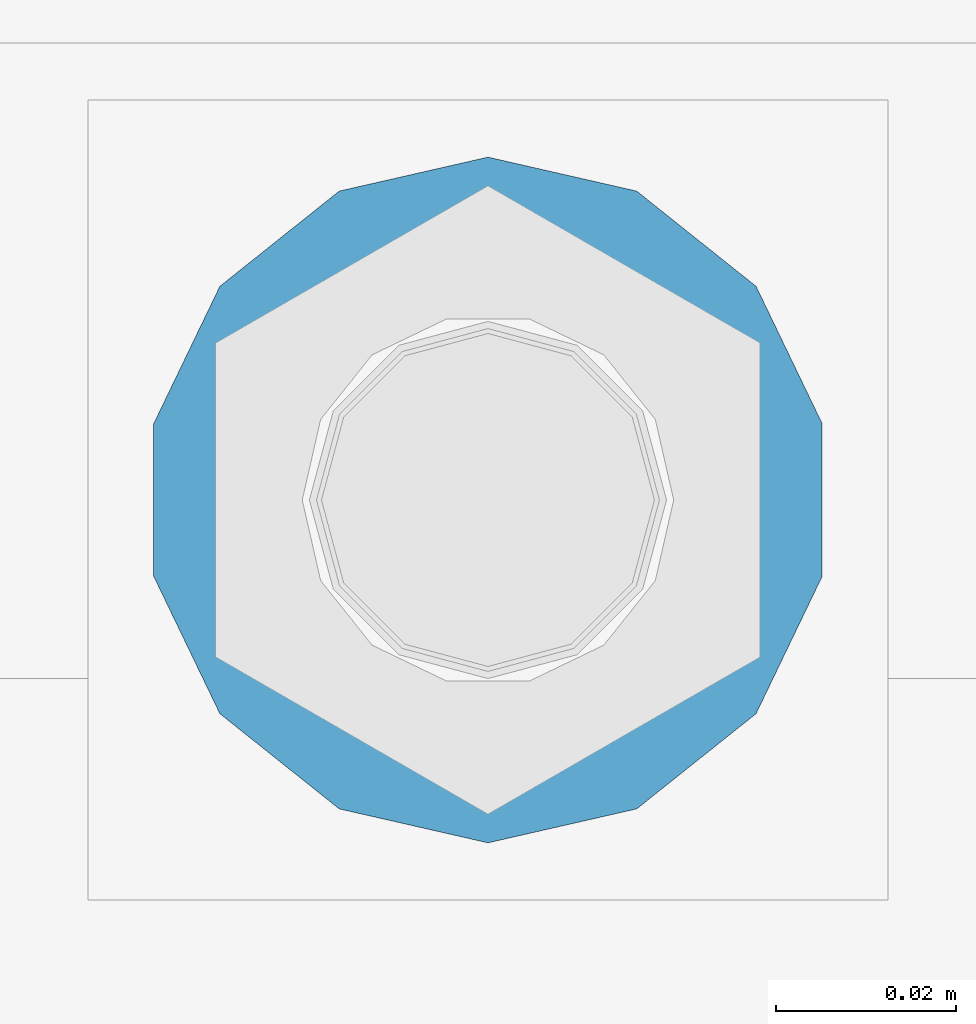
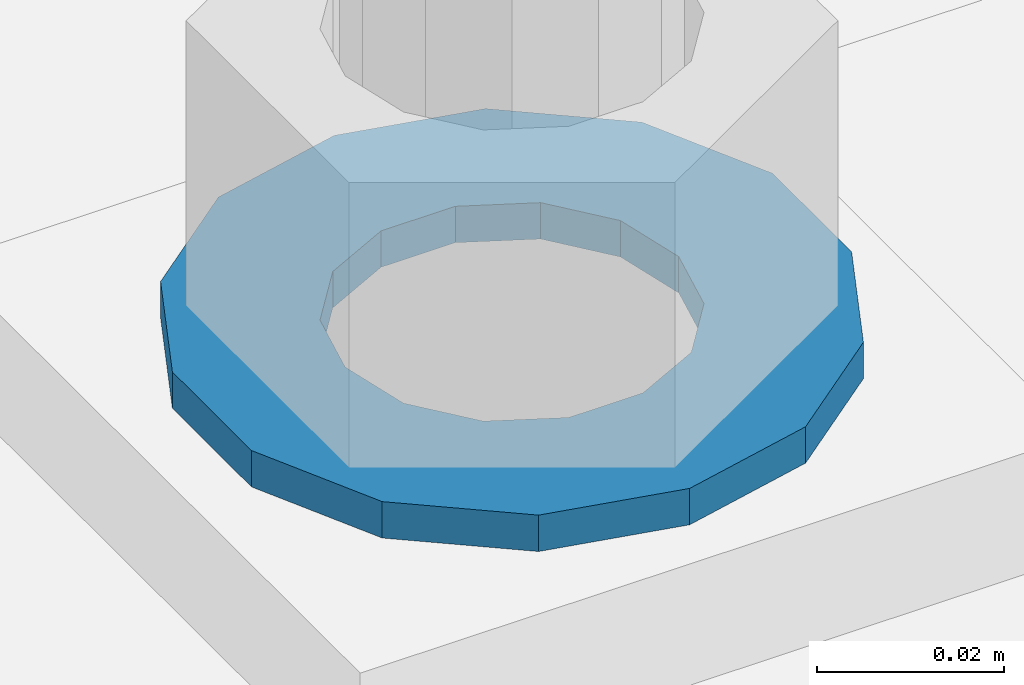
# One storey, part 860 of 1876: 1 column, 1 element without a shape of its own.
"""IFC2X3 building model written with IfcOpenShell, lengths in millimetres."""

import ifcopenshell
import ifcopenshell.guid

model = None  # the IFC model being written
_history = None  # IfcOwnerHistory: only IFC2X3 demands one
_inside = {}  # id of a spatial element -> (the spatial element, [elements in it])
_under = {}  # id of a project, library or spatial element -> (it, [spatial elements below it])
_declared = {}  # id of a project -> (the project, [libraries it declares])
_typed = {}  # id of a type object -> (the type object, [elements of that type])
_made_of = {}  # id of a material, layer set ... -> (it, [elements and type objects made of it])


def new_model(schema):
    """Start an empty IFC model of exactly this schema.

    Asked for "IFC4X3", IfcOpenShell would pick the latest addendum, in which some entities
    have other attributes; the version numbers below select the first issue.
    IFC2X3 requires an IfcOwnerHistory on every rooted entity: one is made here for all.
    """
    global model, _history
    if schema == "IFC4X3":
        model = ifcopenshell.file(schema_version=(4, 3, 0, 0))
    else:
        model = ifcopenshell.file(schema=schema)
    _inside.clear()
    _under.clear()
    _declared.clear()
    _typed.clear()
    _made_of.clear()
    _history = None
    if model.schema == "IFC2X3":
        org = make("IfcOrganization", Name="unknown")
        user = make(
            "IfcPersonAndOrganization",
            ThePerson=make("IfcPerson", FamilyName="unknown"),
            TheOrganization=org,
        )
        app = make(
            "IfcApplication",
            ApplicationDeveloper=org,
            Version="unknown",
            ApplicationFullName="unknown",
            ApplicationIdentifier="unknown",
        )
        _history = make(
            "IfcOwnerHistory",
            OwningUser=user,
            OwningApplication=app,
            ChangeAction="ADDED",
            CreationDate=0,
        )
    return model


def make(cls, **values):
    """One entity of the class cls with the attributes given. An attribute that is None is left unset."""
    return model.create_entity(
        cls, **{name: value for name, value in values.items() if value is not None}
    )


def rooted(cls, **values):
    """An entity with a GlobalId (a new one), such as an element, a storey or a relation."""
    return make(cls, GlobalId=ifcopenshell.guid.new(), OwnerHistory=_history, **values)


def si_unit(unit_type, name, prefix=None):
    """IfcSIUnit, for example si_unit("LENGTHUNIT", "METRE", prefix="MILLI")."""
    return make("IfcSIUnit", UnitType=unit_type, Prefix=prefix, Name=name)


def assignment(units):
    """IfcUnitAssignment: the units of a project."""
    return None if units is None else make("IfcUnitAssignment", Units=units)


def point(xyz):
    """IfcCartesianPoint."""
    return None if xyz is None else make("IfcCartesianPoint", Coordinates=xyz)


def direction(xyz):
    """IfcDirection."""
    return None if xyz is None else make("IfcDirection", DirectionRatios=xyz)


def frame(location, z_axis=None, x_axis=None):
    """IfcAxis2Placement3D, a coordinate frame: its origin and axes. An axis left out is left unset."""
    return make(
        "IfcAxis2Placement3D",
        Location=point(location),
        Axis=direction(z_axis),
        RefDirection=direction(x_axis),
    )


def origin_with_axes():
    """The frame at (0, 0, 0) with the z axis (0, 0, 1) and the x axis (1, 0, 0) written out."""
    return frame((0.0, 0.0, 0.0), z_axis=(0.0, 0.0, 1.0), x_axis=(1.0, 0.0, 0.0))


def place(relative_to, where):
    """IfcLocalPlacement: puts the frame where relative to a parent placement (None: the world)."""
    return make(
        "IfcLocalPlacement", PlacementRelTo=relative_to, RelativePlacement=where
    )


def context(
    kind, dimensions, precision=None, world=None, true_north=None, identifier=None
):
    """IfcGeometricRepresentationContext, for example the 3D "Model" context."""
    return make(
        "IfcGeometricRepresentationContext",
        ContextIdentifier=identifier,
        ContextType=kind,
        CoordinateSpaceDimension=dimensions,
        Precision=precision,
        WorldCoordinateSystem=world,
        TrueNorth=true_north,
    )


def subcontext(parent, identifier, kind, view, scale=None):
    """IfcGeometricRepresentationSubContext, for example "Body" below "Model"."""
    return make(
        "IfcGeometricRepresentationSubContext",
        ContextIdentifier=identifier,
        ContextType=kind,
        ParentContext=parent,
        TargetScale=scale,
        TargetView=view,
    )


def project(units=None, contexts=None):
    """IfcProject with its units and contexts."""
    return rooted(
        "IfcProject",
        Name="project",
        RepresentationContexts=contexts,
        UnitsInContext=assignment(units),
    )


def spatial(cls, under=None, at=None, **own):
    """A site, building, storey or space (cls), placed at a placement, below another one or the project."""
    s = rooted(cls, ObjectPlacement=at, **own)
    if under is not None:
        _under.setdefault(under.id(), (under, []))[1].append(s)
    return s


def faces_of(points, faces, orient=None, outer=None):
    """IfcFace entities. A face is a list of loops; a loop is a list of indices into points, from 0.

    orient and outer hold one flag for each loop. By default every Orientation is true, the
    first loop of a face is its IfcFaceOuterBound and the others are IfcFaceBound.
    """
    made = []
    for i, loops in enumerate(faces):
        bounds = []
        for j, loop in enumerate(loops):
            is_outer = j == 0 if outer is None else outer[i][j]
            bounds.append(
                make(
                    "IfcFaceOuterBound" if is_outer else "IfcFaceBound",
                    Bound=make("IfcPolyLoop", Polygon=[points[k] for k in loop]),
                    Orientation=True if orient is None else orient[i][j],
                )
            )
        made.append(make("IfcFace", Bounds=bounds))
    return made


def faceted_brep(points, faces, orient=None, outer=None, voids=None):
    """IfcFacetedBrep: a solid bounded by flat faces; with voids (closed shells), ...WithVoids."""
    shared = [point(p) for p in points]
    hull = make("IfcClosedShell", CfsFaces=faces_of(shared, faces, orient, outer))
    if voids is None:
        return make("IfcFacetedBrep", Outer=hull)
    return make(
        "IfcFacetedBrepWithVoids",
        Outer=hull,
        Voids=[
            make(cls, CfsFaces=faces_of(shared, fs, o, b)) for cls, fs, o, b in voids
        ],
    )


def shape(context_of_items, identifier, shape_type, items):
    """IfcShapeRepresentation: the items that make up one representation, for example the "Body"."""
    return make(
        "IfcShapeRepresentation",
        ContextOfItems=context_of_items,
        RepresentationIdentifier=identifier,
        RepresentationType=shape_type,
        Items=items,
    )


def material(Name=None, Category=None):
    """IfcMaterial."""
    return make("IfcMaterial", Name=Name, Category=Category)


def made_of(thing, what):
    """Note that an element or type object is made of a material, layer set ...; save() writes the relation."""
    if what is not None:
        _made_of.setdefault(what.id(), (what, []))[1].append(thing)
    return thing


def type_object(cls, material=None, **own):
    """A type object (cls), such as IfcWallType, which elements share."""
    return made_of(rooted(cls, **own), material)


def element(
    cls,
    number,
    at=None,
    inside=None,
    cuts=None,
    type_object=None,
    material=None,
    context=None,
    identifier="Body",
    shape_type=None,
    held_by="IfcProductDefinitionShape",
    body=None,
    shapes=None,
    **own,
):
    """One element of the class cls, such as IfcWall. Its Tag is "e" and its number.

    at: its placement. inside: the storey or other place that contains it. cuts: it is an
    opening in that element (IfcRelVoidsElement). A single representation is given by context,
    identifier, shape_type and body (its items); several are given by shapes. held_by: the class
    of the entity that holds the representations. save() writes the other relations.
    """
    e = rooted(cls, Tag="e%d" % number, ObjectPlacement=at, **own)
    if body is not None:
        shapes = [shape(context, identifier, shape_type, body)]
    if shapes is not None:
        e.Representation = make(held_by, Representations=shapes)
    if inside is not None:
        _inside.setdefault(inside.id(), (inside, []))[1].append(e)
    if cuts is not None:
        rooted(
            "IfcRelVoidsElement", RelatingBuildingElement=cuts, RelatedOpeningElement=e
        )
    if type_object is not None:
        _typed.setdefault(type_object.id(), (type_object, []))[1].append(e)
    return made_of(e, material)


def aggregate(whole, parts):
    """IfcRelAggregates: a whole, such as a stair, and the parts it consists of."""
    return rooted("IfcRelAggregates", RelatingObject=whole, RelatedObjects=parts)


def save(model, path):
    """Write the relations noted so far, then the file.

    IfcRelAggregates (storeys below a building ...), IfcRelContainedInSpatialStructure (elements
    in a storey), IfcRelDefinesByType, IfcRelAssociatesMaterial and IfcRelDeclares: one each for
    every whole, place, type object, material and project.
    """
    for whole, parts in _under.values():
        aggregate(whole, parts)
    for where, things in _inside.values():
        rooted(
            "IfcRelContainedInSpatialStructure",
            RelatedElements=things,
            RelatingStructure=where,
        )
    for kind, things in _typed.values():
        rooted("IfcRelDefinesByType", RelatedObjects=things, RelatingType=kind)
    for what, things in _made_of.values():
        rooted("IfcRelAssociatesMaterial", RelatedObjects=things, RelatingMaterial=what)
    for by, libraries in _declared.values():
        rooted("IfcRelDeclares", RelatingContext=by, RelatedDefinitions=libraries)
    model.write(path)


model = new_model("IFC2X3")

# Units and contexts
model_context = context("Model", 3, precision=1e-05, world=origin_with_axes())
body_context = subcontext(model_context, "Body", "Model", "MODEL_VIEW")
ifc_project = project(units=[si_unit("LENGTHUNIT", "METRE", prefix="MILLI"), si_unit("AREAUNIT", "SQUARE_METRE"), si_unit("VOLUMEUNIT", "CUBIC_METRE"), si_unit("MASSUNIT", "GRAM", prefix="KILO"), si_unit("TIMEUNIT", "SECOND"), si_unit("PLANEANGLEUNIT", "RADIAN"), si_unit("SOLIDANGLEUNIT", "STERADIAN"), si_unit("THERMODYNAMICTEMPERATUREUNIT", "DEGREE_CELSIUS"), si_unit("LUMINOUSINTENSITYUNIT", "LUMEN")], contexts=[model_context])

# Site, building, storey
site_placement = place(None, origin_with_axes())
site = spatial("IfcSite", under=ifc_project, at=site_placement, CompositionType="ELEMENT")
building_placement = place(site_placement, origin_with_axes())
building = spatial("IfcBuilding", under=site, at=building_placement, Name="Undefined", CompositionType="ELEMENT")
storey_placement = place(building_placement, origin_with_axes())
storey = spatial("IfcBuildingStorey", under=building, at=storey_placement, Name="Undefined", CompositionType="ELEMENT", Elevation=0.0)

# Assembly, column
assembly_placement = place(storey_placement, origin_with_axes())
assembly = element("IfcElementAssembly", 1, at=assembly_placement, inside=storey, Name="TEMPLATE", AssemblyPlace="NOTDEFINED", PredefinedType="RIGID_FRAME")
ifc_material = material(Name="STEEL/F436")
column_type = type_object("IfcColumnType", Name="1-1/2_WASHER", PredefinedType="NOTDEFINED")
column_placement = place(assembly_placement, frame((7620.0, 13893.8, 109.5375), z_axis=(-1.0, 0.0, 0.0), x_axis=(0.0, 0.0, -1.0)))
column = element("IfcColumn", 2, at=column_placement, type_object=column_type, material=ifc_material, Name="WASHER", ObjectType="1-1/2_WASHER", context=body_context, shape_type="Brep", body=[
    faceted_brep([(0.0, -38.0999984741211, 0.0), (0.0, -34.3269124923136, -16.5309697983251), (4.7625, -34.3269124923136, -16.5309697983251), (4.7625, -38.0999984741211, 0.0), (0.0, -23.7549604994474, -29.787778289052), (4.7625, -23.7549604994474, -29.787778289052), (0.0, -8.4780472441962, -37.1447519665058), (4.7625, -8.4780472441962, -37.1447519665058), (0.0, 8.4780472441962, -37.1447519665058), (4.7625, 8.4780472441962, -37.1447519665058), (0.0, 23.7549604994474, -29.787778289052), (4.7625, 23.7549604994474, -29.787778289052), (0.0, 34.3269124923136, -16.5309697983251), (4.7625, 34.3269124923136, -16.5309697983251), (0.0, 38.0999984741211, 0.0), (4.7625, 38.0999984741211, 0.0), (0.0, 34.3269124923136, 16.5309697983251), (4.7625, 34.3269124923136, 16.5309697983251), (0.0, 23.7549604994474, 29.787778289052), (4.7625, 23.7549604994474, 29.787778289052), (0.0, 8.4780472441962, 37.1447519665058), (4.7625, 8.4780472441962, 37.1447519665058), (0.0, -8.4780472441962, 37.1447519665058), (4.7625, -8.4780472441962, 37.1447519665058), (0.0, -23.7549604994474, 29.787778289052), (4.7625, -23.7549604994474, 29.787778289052), (0.0, -34.3269124923136, 16.5309697983251), (4.7625, -34.3269124923136, 16.5309697983251), (0.0, 0.0, 20.6399993896484), (0.0, 8.95536011056538, 18.5959968835978), (4.7625, 8.95536011056538, 18.595996883598), (4.7625, 0.0, 20.6399993896484), (0.0, 16.1370013209489, 12.8688291298158), (4.7625, 16.1370013209489, 12.8688291298162), (0.0, 20.1225115123834, 4.59283194104228), (4.7625, 20.1225115123834, 4.59283194104222), (0.0, 20.1225115123834, -4.59283194104228), (4.7625, 20.1225115123834, -4.59283194104242), (0.0, 16.1370013209489, -12.8688291298167), (4.7625, 16.1370013209489, -12.8688291298163), (0.0, 8.95536011056538, -18.5959968835978), (4.7625, 8.95536011056538, -18.5959968835982), (0.0, 0.0, -20.6399993896484), (4.7625, 0.0, -20.6399993896484), (0.0, -8.95536011056538, -18.5959968835978), (4.7625, -8.95536011056538, -18.595996883598), (0.0, -16.1370013209489, -12.8688291298158), (4.7625, -16.1370013209489, -12.8688291298162), (0.0, -20.1225115123834, -4.59283194104228), (4.7625, -20.1225115123834, -4.59283194104222), (0.0, -20.1225115123834, 4.59283194104228), (4.7625, -20.1225115123834, 4.59283194104242), (0.0, -16.1370013209489, 12.8688291298167), (4.7625, -16.1370013209489, 12.8688291298163), (0.0, -8.95536011056538, 18.5959968835978), (4.7625, -8.95536011056538, 18.5959968835982)], [[[0, 1, 2, 3]], [[1, 4, 5, 2]], [[4, 6, 7, 5]], [[6, 8, 9, 7]], [[8, 10, 11, 9]], [[10, 12, 13, 11]], [[12, 14, 15, 13]], [[14, 16, 17, 15]], [[16, 18, 19, 17]], [[18, 20, 21, 19]], [[20, 22, 23, 21]], [[22, 24, 25, 23]], [[24, 26, 27, 25]], [[26, 0, 3, 27]], [[28, 29, 30, 31]], [[29, 32, 33, 30]], [[32, 34, 35, 33]], [[34, 36, 37, 35]], [[36, 38, 39, 37]], [[38, 40, 41, 39]], [[40, 42, 43, 41]], [[42, 44, 45, 43]], [[44, 46, 47, 45]], [[46, 48, 49, 47]], [[48, 50, 51, 49]], [[50, 52, 53, 51]], [[52, 54, 55, 53]], [[54, 28, 31, 55]], [[5, 7, 9, 11, 13, 15, 17, 19, 21, 23, 25, 27, 3, 2], [33, 35, 37, 39, 41, 43, 45, 47, 49, 51, 53, 55, 31, 30]], [[26, 24, 22, 20, 18, 16, 14, 12, 10, 8, 6, 4, 1, 0], [54, 52, 50, 48, 46, 44, 42, 40, 38, 36, 34, 32, 29, 28]]]),
])
aggregate(assembly, [column])

save(model, "model.ifc")
